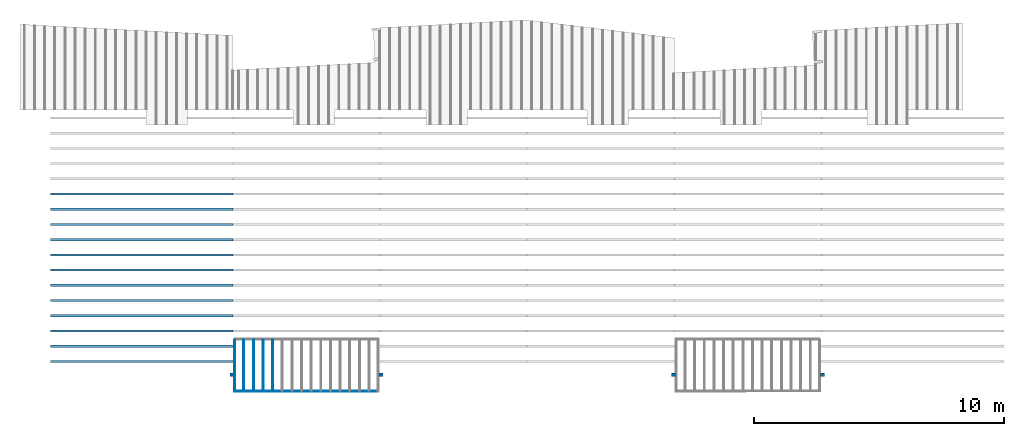
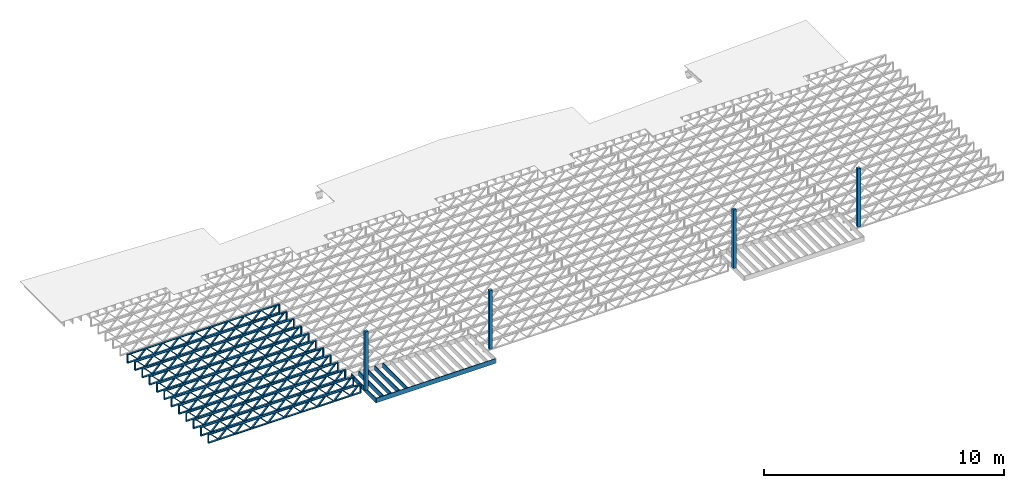
# One storey, part 1 of 12: 18 beams, 4 columns, 2 elements without a shape of their own.
"""IFC4 building model written with IfcOpenShell, lengths in feet."""

from ifc_helpers import new_model, entity, si_unit, converted_unit, derived_unit, direction, frame, frame_2d, origin, origin_2d_with_axis, place, context, subcontext, project, spatial, rectangle, extrude, source, transform, mapped, material, material_profile, profile_set, profile_usage, type_object, type_shapes, element, aggregate, save


model = new_model("IFC4")

# Units and contexts
model_context = context("Model", 3, precision=0.0001, world=origin(), true_north=direction((6.12303176911189e-17, 1.0)))
body_context = subcontext(model_context, "Body", "Model", "MODEL_VIEW")
ifc_project = project(units=[converted_unit("LENGTHUNIT", "FOOT", entity("IfcRatioMeasure", 0.3048), si_unit("LENGTHUNIT", "METRE"), dimensions=[1, 0, 0, 0, 0, 0, 0]), converted_unit("AREAUNIT", "SQUARE FOOT", entity("IfcRatioMeasure", 0.09290304), si_unit("AREAUNIT", "SQUARE_METRE"), dimensions=[2, 0, 0, 0, 0, 0, 0]), converted_unit("VOLUMEUNIT", "CUBIC FOOT", entity("IfcRatioMeasure", 0.028316846592), si_unit("VOLUMEUNIT", "CUBIC_METRE"), dimensions=[3, 0, 0, 0, 0, 0, 0]), converted_unit("PLANEANGLEUNIT", "DEGREE", entity("IfcRatioMeasure", 0.0174532925199433), si_unit("PLANEANGLEUNIT", "RADIAN"), dimensions=[0, 0, 0, 0, 0, 0, 0]), si_unit("MASSUNIT", "GRAM", prefix="KILO"), derived_unit("MASSDENSITYUNIT", [(si_unit("MASSUNIT", "GRAM", prefix="KILO"), 1), (si_unit("LENGTHUNIT", "METRE"), -3)]), derived_unit("MOMENTOFINERTIAUNIT", [(si_unit("LENGTHUNIT", "METRE"), 4)]), si_unit("TIMEUNIT", "SECOND"), si_unit("FREQUENCYUNIT", "HERTZ"), si_unit("THERMODYNAMICTEMPERATUREUNIT", "DEGREE_CELSIUS"), derived_unit("THERMALTRANSMITTANCEUNIT", [(si_unit("MASSUNIT", "GRAM", prefix="KILO"), 1), (si_unit("THERMODYNAMICTEMPERATUREUNIT", "KELVIN"), -1), (si_unit("TIMEUNIT", "SECOND"), -3)]), derived_unit("VOLUMETRICFLOWRATEUNIT", [(si_unit("LENGTHUNIT", "METRE"), 3), (si_unit("TIMEUNIT", "SECOND"), -1)]), si_unit("ELECTRICCURRENTUNIT", "AMPERE"), si_unit("ELECTRICVOLTAGEUNIT", "VOLT"), si_unit("POWERUNIT", "WATT"), si_unit("FORCEUNIT", "NEWTON"), si_unit("ILLUMINANCEUNIT", "LUX"), si_unit("LUMINOUSFLUXUNIT", "LUMEN"), si_unit("LUMINOUSINTENSITYUNIT", "CANDELA"), derived_unit("USERDEFINED", [(si_unit("MASSUNIT", "GRAM", prefix="KILO"), -1), (si_unit("LENGTHUNIT", "METRE"), -2), (si_unit("TIMEUNIT", "SECOND"), 3), (si_unit("LUMINOUSFLUXUNIT", "LUMEN"), 1)]), derived_unit("LINEARVELOCITYUNIT", [(si_unit("LENGTHUNIT", "METRE"), 1), (si_unit("TIMEUNIT", "SECOND"), -1)]), si_unit("PRESSUREUNIT", "PASCAL"), derived_unit("USERDEFINED", [(si_unit("LENGTHUNIT", "METRE"), -2), (si_unit("MASSUNIT", "GRAM", prefix="KILO"), 1), (si_unit("TIMEUNIT", "SECOND"), -2)]), derived_unit("LINEARFORCEUNIT", [(si_unit("MASSUNIT", "GRAM", prefix="KILO"), 1), (si_unit("LENGTHUNIT", "METRE"), 1), (si_unit("TIMEUNIT", "SECOND"), -2), (si_unit("LENGTHUNIT", "METRE"), -1)]), derived_unit("PLANARFORCEUNIT", [(si_unit("MASSUNIT", "GRAM", prefix="KILO"), 1), (si_unit("LENGTHUNIT", "METRE"), 1), (si_unit("TIMEUNIT", "SECOND"), -2), (si_unit("LENGTHUNIT", "METRE"), -2)])], contexts=[model_context])

# Site, building, storey
site_placement = place(None, origin())
site = spatial("IfcSite", under=ifc_project, at=site_placement, CompositionType="ELEMENT")
building_placement = place(site_placement, origin())
building = spatial("IfcBuilding", under=site, at=building_placement, CompositionType="ELEMENT")
storey_placement = place(building_placement, frame((0.0, 0.0, 21.46875)))
storey = spatial("IfcBuildingStorey", under=building, at=storey_placement, Name="3RD FLOOR", CompositionType="ELEMENT", Elevation=21.46875)

# Columns
ifc_material_1 = material(Name="STRUCTURAL WOOD COLUMN - SIZE TBD", Category="Materials")
ifc_material_profile_1 = material_profile(ifc_material_1, rectangle(XDim=0.458333333333333, YDim=0.5, at=frame_2d((0.0, -2.77555756156289e-17), x_axis=(1.0, 0.0))), Name="(4) 2X6 - BUILT-UP COLUMN")
ifc_profile_set_1 = profile_set([ifc_material_profile_1], Name="(4) 2X6 - BUILT-UP COLUMN")
ifc_profile_usage_1 = profile_usage(ifc_profile_set_1)
column_type = type_object("IfcColumnType", Name="Timber-Column:(4) 2X6 - BUILT-UP COLUMN", PredefinedType="COLUMN", material=ifc_profile_set_1)
shared_shape_1 = source(origin(), body_context, "Body", "SweptSolid", [
    extrude(rectangle(XDim=0.458333333333333, YDim=0.5, at=frame_2d((0.0, -2.77555756156289e-17), x_axis=(1.0, 0.0))), frame((0.0, 0.0, 21.46875), z_axis=(0.0, 0.0, 1.0), x_axis=(0.0, -1.0, 0.0)), (0.0, 0.0, 1.0), 9.73958333334152),
])
type_shapes(column_type, [shared_shape_1])
column_1_placement = place(storey_placement, frame((-241.863160485529, 924.091101549317, -21.46875)))
element("IfcColumn", 1, at=column_1_placement, inside=storey, type_object=column_type, material=ifc_profile_usage_1, Name="Timber-Column:(4) 2X6 - BUILT-UP COLUMN", ObjectType="Timber-Column:(4) 2X6 - BUILT-UP COLUMN", PredefinedType="COLUMN", context=body_context, shape_type="MappedRepresentation", body=[
    mapped(shared_shape_1, transform((0.0, 0.0, 0.0), scale=1.0)),
])
ifc_profile_usage_2 = profile_usage(ifc_profile_set_1)
column_2_placement = place(storey_placement, frame((-222.279828726425, 924.091101549317, -21.46875)))
element("IfcColumn", 2, at=column_2_placement, inside=storey, type_object=column_type, material=ifc_profile_usage_2, Name="Timber-Column:(4) 2X6 - BUILT-UP COLUMN", ObjectType="Timber-Column:(4) 2X6 - BUILT-UP COLUMN", PredefinedType="COLUMN", context=body_context, shape_type="MappedRepresentation", body=[
    mapped(shared_shape_1, transform((0.0, 0.0, 0.0), scale=1.0)),
])
ifc_profile_usage_3 = profile_usage(ifc_profile_set_1)
column_3_placement = place(storey_placement, frame((-183.863160485529, 924.091101549317, -21.46875)))
element("IfcColumn", 3, at=column_3_placement, inside=storey, type_object=column_type, material=ifc_profile_usage_3, Name="Timber-Column:(4) 2X6 - BUILT-UP COLUMN", ObjectType="Timber-Column:(4) 2X6 - BUILT-UP COLUMN", PredefinedType="COLUMN", context=body_context, shape_type="MappedRepresentation", body=[
    mapped(shared_shape_1, transform((0.0, 0.0, 0.0), scale=1.0)),
])
ifc_profile_usage_4 = profile_usage(ifc_profile_set_1)
column_4_placement = place(storey_placement, frame((-164.279827152195, 924.091101549317, -21.46875)))
element("IfcColumn", 4, at=column_4_placement, inside=storey, type_object=column_type, material=ifc_profile_usage_4, Name="Timber-Column:(4) 2X6 - BUILT-UP COLUMN", ObjectType="Timber-Column:(4) 2X6 - BUILT-UP COLUMN", PredefinedType="COLUMN", context=body_context, shape_type="MappedRepresentation", body=[
    mapped(shared_shape_1, transform((0.0, 0.0, 0.0), scale=1.0)),
])

# Assembly, beams
assembly_1_placement = place(storey_placement, origin())
assembly_1 = element("IfcElementAssembly", 5, at=assembly_1_placement, inside=storey, Name="Structural Beam System:Structural Framing System", ObjectType="Structural Beam System:Structural Framing System", AssemblyPlace="NOTDEFINED", PredefinedType="BEAM_GRID")
ifc_material_2 = material(Category="Materials")
ifc_material_profile_2 = material_profile(ifc_material_2, rectangle(XDim=0.770833333333333, YDim=0.124999999999994, at=frame_2d((-5.55111512312578e-17, 0.0), x_axis=(1.0, 0.0))))
ifc_profile_set_2 = profile_set([ifc_material_profile_2])
ifc_profile_usage_5 = profile_usage(ifc_profile_set_2, cardinal=8)
beam_type_1 = type_object("IfcBeamType", PredefinedType="BEAM", material=ifc_profile_set_2)
shared_shape_2 = source(origin(), body_context, "Body", "SweptSolid", [
    extrude(rectangle(XDim=0.770833333333333, YDim=0.124999999999994, at=frame_2d((-5.55111512312578e-17, 0.0), x_axis=(1.0, 0.0))), frame((-3.35416666666737, 0.0, 0.0), z_axis=(1.0, 0.0, 0.0), x_axis=(0.0, 0.0, -1.0)), (0.0, 0.0, 1.0), 6.70833333333462),
])
type_shapes(beam_type_1, [shared_shape_2])
beam_1_placement = place(assembly_1_placement, frame((-240.307864400484, 925.341101549316, -0.645833333333474), z_axis=(0.0, 0.0, 1.0), x_axis=(0.0, 1.0, 0.0)))
beam_1 = element("IfcBeam", 6, at=beam_1_placement, type_object=beam_type_1, material=ifc_profile_usage_5, PredefinedType="BEAM", context=body_context, shape_type="MappedRepresentation", body=[
    mapped(shared_shape_2, transform((0.0, 0.0, 0.0), scale=1.0)),
])
ifc_profile_usage_6 = profile_usage(ifc_profile_set_2, cardinal=8)
beam_2_placement = place(assembly_1_placement, frame((-239.040980719926, 925.341101549316, -0.645833333333474), z_axis=(0.0, 0.0, 1.0), x_axis=(0.0, 1.0, 0.0)))
beam_2 = element("IfcBeam", 7, at=beam_2_placement, type_object=beam_type_1, material=ifc_profile_usage_6, PredefinedType="BEAM", context=body_context, shape_type="MappedRepresentation", body=[
    mapped(shared_shape_2, transform((0.0, 0.0, 0.0), scale=1.0)),
])
ifc_profile_usage_7 = profile_usage(ifc_profile_set_2, cardinal=8)
beam_3_placement = place(assembly_1_placement, frame((-237.774097039367, 925.341101549316, -0.645833333333474), z_axis=(0.0, 0.0, 1.0), x_axis=(0.0, 1.0, 0.0)))
beam_3 = element("IfcBeam", 8, at=beam_3_placement, type_object=beam_type_1, material=ifc_profile_usage_7, PredefinedType="BEAM", context=body_context, shape_type="MappedRepresentation", body=[
    mapped(shared_shape_2, transform((0.0, 0.0, 0.0), scale=1.0)),
])
ifc_profile_usage_8 = profile_usage(ifc_profile_set_2, cardinal=8)
beam_4_placement = place(assembly_1_placement, frame((-236.507213358809, 925.341101549317, -0.645833333333474), z_axis=(0.0, 0.0, 1.0), x_axis=(0.0, 1.0, 0.0)))
beam_4 = element("IfcBeam", 9, at=beam_4_placement, type_object=beam_type_1, material=ifc_profile_usage_8, PredefinedType="BEAM", context=body_context, shape_type="MappedRepresentation", body=[
    mapped(shared_shape_2, transform((0.0, 0.0, 0.0), scale=1.0)),
])
aggregate(assembly_1, [beam_1, beam_2, beam_3, beam_4])

assembly_2_placement = place(storey_placement, origin())
assembly_2 = element("IfcElementAssembly", 10, at=assembly_2_placement, inside=storey, Name="Structural Beam System:Structural Framing System", ObjectType="Structural Beam System:Structural Framing System", AssemblyPlace="NOTDEFINED", PredefinedType="BEAM_GRID")
ifc_material_3 = material(Name="WOOD TRUSS", Category="Materials")
ifc_material_profile_3 = material_profile(ifc_material_3, rectangle(XDim=1.73473973950632, YDim=0.125, at=frame_2d((-1.11022302462516e-16, 8.32667268468867e-17), x_axis=(1.0, 0.0))))
ifc_material_profile_4 = material_profile(ifc_material_3, rectangle(XDim=1.73473973950633, YDim=0.125, at=frame_2d((-1.11022302462516e-16, 8.32667268468867e-17), x_axis=(1.0, 0.0))))
ifc_material_profile_5 = material_profile(ifc_material_3, rectangle(XDim=1.73473973950632, YDim=0.125, at=frame_2d((-5.55111512312578e-17, 1.38777878078145e-16), x_axis=(1.0, 0.0))))
ifc_material_profile_6 = material_profile(ifc_material_3, rectangle(XDim=1.73473973950633, YDim=0.125, at=frame_2d((-1.11022302462516e-16, 8.32667268468867e-17), x_axis=(1.0, 0.0))))
ifc_material_profile_7 = material_profile(ifc_material_3, rectangle(XDim=1.73473973950632, YDim=0.125, at=frame_2d((-1.11022302462516e-16, 8.32667268468867e-17), x_axis=(1.0, 0.0))))
ifc_material_profile_8 = material_profile(ifc_material_3, rectangle(XDim=1.73473973950633, YDim=0.125, at=frame_2d((-2.77555756156289e-16, 3.05311331771918e-16), x_axis=(1.0, 0.0))))
ifc_material_profile_9 = material_profile(ifc_material_3, rectangle(XDim=1.73473973950632, YDim=0.124999999999999, at=frame_2d((-3.88578058618805e-16, -2.4980018054066e-16), x_axis=(1.0, 0.0))))
ifc_material_profile_10 = material_profile(ifc_material_3, rectangle(XDim=1.73473973950633, YDim=0.125, at=frame_2d((2.77555756156289e-16, -3.05311331771918e-16), x_axis=(1.0, 0.0))))
ifc_material_profile_11 = material_profile(ifc_material_3, rectangle(XDim=1.73473973950632, YDim=0.124999999999999, at=frame_2d((-1.11022302462516e-16, 8.32667268468867e-17), x_axis=(1.0, 0.0))))
ifc_material_profile_12 = material_profile(ifc_material_3, rectangle(XDim=1.73473973950633, YDim=0.125, at=origin_2d_with_axis()))
ifc_material_profile_13 = material_profile(ifc_material_3, rectangle(XDim=0.124999999999982, YDim=0.291666666666668, at=origin_2d_with_axis()))
ifc_material_profile_14 = material_profile(ifc_material_3, rectangle(XDim=0.124999999999932, YDim=0.291666666666664, at=origin_2d_with_axis()))
ifc_material_profile_15 = material_profile(ifc_material_3, rectangle(XDim=1.25000000000002, YDim=0.29166666666667, at=origin_2d_with_axis()))
ifc_material_profile_16 = material_profile(ifc_material_3, rectangle(XDim=1.25000000000004, YDim=0.291666666666667, at=origin_2d_with_axis()))
ifc_profile_set_3 = profile_set([ifc_material_profile_3, ifc_material_profile_4, ifc_material_profile_5, ifc_material_profile_6, ifc_material_profile_7, ifc_material_profile_8, ifc_material_profile_9, ifc_material_profile_10, ifc_material_profile_11, ifc_material_profile_12, ifc_material_profile_13, ifc_material_profile_14, ifc_material_profile_15, ifc_material_profile_16])
ifc_profile_usage_9 = profile_usage(ifc_profile_set_3, cardinal=8)
beam_type_2 = type_object("IfcBeamType", PredefinedType="BEAM", material=ifc_profile_set_3)
shared_shape_3 = source(origin(), body_context, "Body", "SweptSolid", [
    extrude(rectangle(XDim=1.73473973950632, YDim=0.124999999999999, at=frame_2d((5.55111512312578e-16, 7.21644966006352e-16), x_axis=(1.0, 0.0))), frame((8.37514585578398, -0.145833333333334, 0.0), z_axis=(0.0, 1.0, 0.0), x_axis=(0.693383046997606, 0.0, 0.720569184836762)), (0.0, 0.0, 1.0), 0.291666666666667),
    extrude(rectangle(XDim=1.73473973950633, YDim=0.125, at=origin_2d_with_axis()), frame((7.12485998211071, -0.145833333333334, 0.0), z_axis=(0.0, 1.0, 0.0), x_axis=(0.69338304699761, 0.0, -0.720569184836758)), (0.0, 0.0, 1.0), 0.291666666666666),
    extrude(rectangle(XDim=1.73473973950632, YDim=0.124999999999999, at=frame_2d((-1.11022302462516e-16, 8.32667268468867e-17), x_axis=(1.0, 0.0))), frame((5.79181154946831, -0.145833333333334, 0.0), z_axis=(0.0, 1.0, 0.0), x_axis=(0.693383046997606, 0.0, 0.720569184836762)), (0.0, 0.0, 1.0), 0.291666666666667),
    extrude(rectangle(XDim=1.73473973950633, YDim=0.125, at=origin_2d_with_axis()), frame((4.54152567579504, -0.145833333333334, 0.0), z_axis=(0.0, 1.0, 0.0), x_axis=(0.69338304699761, 0.0, -0.720569184836758)), (0.0, 0.0, 1.0), 0.291666666666666),
    extrude(rectangle(XDim=1.73473973950632, YDim=0.125, at=frame_2d((2.22044604925031e-16, 3.88578058618805e-16), x_axis=(1.0, 0.0))), frame((3.20847724315264, -0.145833333333334, 0.0), z_axis=(0.0, 1.0, 0.0), x_axis=(0.693383046997606, 0.0, 0.720569184836762)), (0.0, 0.0, 1.0), 0.291666666666667),
    extrude(rectangle(XDim=1.73473973950633, YDim=0.125, at=frame_2d((-1.11022302462516e-16, 8.32667268468867e-17), x_axis=(1.0, 0.0))), frame((1.95819136947937, -0.145833333333334, 0.0), z_axis=(0.0, 1.0, 0.0), x_axis=(0.69338304699761, 0.0, -0.720569184836758)), (0.0, 0.0, 1.0), 0.291666666666667),
    extrude(rectangle(XDim=1.73473973950632, YDim=0.125, at=frame_2d((-5.55111512312578e-17, 1.38777878078145e-16), x_axis=(1.0, 0.0))), frame((0.625142936836964, -0.145833333333334, 0.0), z_axis=(0.0, 1.0, 0.0), x_axis=(0.693383046997606, 0.0, 0.720569184836762)), (0.0, 0.0, 1.0), 0.291666666666667),
    extrude(rectangle(XDim=1.73473973950633, YDim=0.125, at=frame_2d((-1.11022302462516e-16, 8.32667268468867e-17), x_axis=(1.0, 0.0))), frame((-0.625142936836306, -0.145833333333334, 0.0), z_axis=(0.0, 1.0, 0.0), x_axis=(0.69338304699761, 0.0, -0.720569184836758)), (0.0, 0.0, 1.0), 0.291666666666667),
    extrude(rectangle(XDim=1.73473973950632, YDim=0.125, at=frame_2d((-1.11022302462516e-16, 8.32667268468867e-17), x_axis=(1.0, 0.0))), frame((-1.95819136947871, -0.145833333333334, 0.0), z_axis=(0.0, 1.0, 0.0), x_axis=(0.693383046997606, 0.0, 0.720569184836762)), (0.0, 0.0, 1.0), 0.291666666666667),
    extrude(rectangle(XDim=1.73473973950633, YDim=0.125, at=origin_2d_with_axis()), frame((-3.20847724315198, -0.145833333333334, 0.0), z_axis=(0.0, 1.0, 0.0), x_axis=(0.69338304699761, 0.0, -0.720569184836758)), (0.0, 0.0, 1.0), 0.291666666666667),
    extrude(rectangle(XDim=1.73473973950632, YDim=0.124999999999999, at=frame_2d((-1.11022302462516e-16, 8.32667268468867e-17), x_axis=(1.0, 0.0))), frame((-4.54152567579438, -0.145833333333334, 0.0), z_axis=(0.0, 1.0, 0.0), x_axis=(0.693383046997606, 0.0, 0.720569184836762)), (0.0, 0.0, 1.0), 0.291666666666667),
    extrude(rectangle(XDim=1.73473973950633, YDim=0.125, at=origin_2d_with_axis()), frame((-5.79181154946765, -0.145833333333334, 0.0), z_axis=(0.0, 1.0, 0.0), x_axis=(0.69338304699761, 0.0, -0.720569184836758)), (0.0, 0.0, 1.0), 0.291666666666666),
    extrude(rectangle(XDim=1.73473973950632, YDim=0.124999999999999, at=frame_2d((-1.11022302462516e-16, 8.32667268468867e-17), x_axis=(1.0, 0.0))), frame((-7.12485998211005, -0.145833333333334, 0.0), z_axis=(0.0, 1.0, 0.0), x_axis=(0.693383046997606, 0.0, 0.720569184836762)), (0.0, 0.0, 1.0), 0.291666666666667),
    extrude(rectangle(XDim=1.73473973950633, YDim=0.125, at=frame_2d((-2.77555756156289e-16, 3.05311331771918e-16), x_axis=(1.0, 0.0))), frame((-8.37514585578332, -0.145833333333334, 0.0), z_axis=(0.0, 1.0, 0.0), x_axis=(0.69338304699761, 0.0, -0.720569184836758)), (0.0, 0.0, 1.0), 0.291666666666666),
    extrude(rectangle(XDim=1.73473973950632, YDim=0.125, at=frame_2d((-7.21644966006352e-16, -5.55111512312578e-16), x_axis=(1.0, 0.0))), frame((10.9584801620997, -0.145833333333334, 0.0), z_axis=(0.0, 1.0, 0.0), x_axis=(0.693383046997606, 0.0, 0.720569184836762)), (0.0, 0.0, 1.0), 0.291666666666667),
    extrude(rectangle(XDim=1.73473973950633, YDim=0.125, at=origin_2d_with_axis()), frame((9.70819428842638, -0.145833333333334, 0.0), z_axis=(0.0, 1.0, 0.0), x_axis=(0.69338304699761, 0.0, -0.720569184836758)), (0.0, 0.0, 1.0), 0.291666666666666),
    extrude(rectangle(XDim=1.73473973950632, YDim=0.125, at=frame_2d((-5.55111512312578e-17, 8.32667268468867e-17), x_axis=(1.0, 0.0))), frame((-9.70819428842572, -0.145833333333334, 0.0), z_axis=(0.0, 1.0, 0.0), x_axis=(0.693383046997606, 0.0, 0.720569184836762)), (0.0, 0.0, 1.0), 0.291666666666667),
    extrude(rectangle(XDim=1.73473973950633, YDim=0.125, at=origin_2d_with_axis()), frame((-10.958480162099, -0.145833333333334, 0.0), z_axis=(0.0, 1.0, 0.0), x_axis=(0.69338304699761, 0.0, -0.720569184836758)), (0.0, 0.0, 1.0), 0.291666666666666),
    extrude(rectangle(XDim=0.124999999999982, YDim=0.291666666666668, at=origin_2d_with_axis()), frame((-12.0000038919293, 0.0, 0.687500000000054), z_axis=(1.0, 0.0, 0.0), x_axis=(0.0, 0.0, -1.0)), (0.0, 0.0, 1.0), 24.0000077838585),
    extrude(rectangle(XDim=0.124999999999932, YDim=0.291666666666664, at=origin_2d_with_axis()), frame((-12.0000038919291, 0.0, -0.687499999999984), z_axis=(1.0, 0.0, 0.0), x_axis=(0.0, 0.0, -1.0)), (0.0, 0.0, 1.0), 24.0000077838583),
    extrude(rectangle(XDim=1.25000000000002, YDim=0.29166666666667, at=origin_2d_with_axis()), frame((11.8750038919292, 0.0, 0.0), z_axis=(1.0, 0.0, 0.0), x_axis=(0.0, 0.0, -1.0)), (0.0, 0.0, 1.0), 0.12500000000002),
    extrude(rectangle(XDim=1.25000000000004, YDim=0.291666666666667, at=origin_2d_with_axis()), frame((-12.0000038919293, 0.0, 0.0), z_axis=(1.0, 0.0, 0.0), x_axis=(0.0, 0.0, -1.0)), (0.0, 0.0, 1.0), 0.125000000000023),
])
type_shapes(beam_type_2, [shared_shape_3])
beam_5_placement = place(assembly_2_placement, frame((-253.738164405664, 947.861934882651, -0.947916666657857)))
beam_5 = element("IfcBeam", 11, at=beam_5_placement, type_object=beam_type_2, material=ifc_profile_usage_9, PredefinedType="BEAM", context=body_context, shape_type="MappedRepresentation", body=[
    mapped(shared_shape_3, transform((0.0, 0.0, 0.0), scale=1.0)),
])
ifc_profile_usage_10 = profile_usage(ifc_profile_set_3, cardinal=8)
beam_6_placement = place(assembly_2_placement, frame((-253.738164405664, 945.861934882651, -0.947916666657857)))
beam_6 = element("IfcBeam", 12, at=beam_6_placement, type_object=beam_type_2, material=ifc_profile_usage_10, PredefinedType="BEAM", context=body_context, shape_type="MappedRepresentation", body=[
    mapped(shared_shape_3, transform((0.0, 0.0, 0.0), scale=1.0)),
])
ifc_profile_usage_11 = profile_usage(ifc_profile_set_3, cardinal=8)
beam_7_placement = place(assembly_2_placement, frame((-253.738164405664, 943.861934882651, -0.947916666657857)))
beam_7 = element("IfcBeam", 13, at=beam_7_placement, type_object=beam_type_2, material=ifc_profile_usage_11, PredefinedType="BEAM", context=body_context, shape_type="MappedRepresentation", body=[
    mapped(shared_shape_3, transform((0.0, 0.0, 0.0), scale=1.0)),
])
ifc_profile_usage_12 = profile_usage(ifc_profile_set_3, cardinal=8)
beam_8_placement = place(assembly_2_placement, frame((-253.738164405664, 941.861934882651, -0.947916666657857)))
beam_8 = element("IfcBeam", 14, at=beam_8_placement, type_object=beam_type_2, material=ifc_profile_usage_12, PredefinedType="BEAM", context=body_context, shape_type="MappedRepresentation", body=[
    mapped(shared_shape_3, transform((0.0, 0.0, 0.0), scale=1.0)),
])
ifc_profile_usage_13 = profile_usage(ifc_profile_set_3, cardinal=8)
beam_9_placement = place(assembly_2_placement, frame((-253.738164405664, 939.861934882651, -0.947916666657857)))
beam_9 = element("IfcBeam", 15, at=beam_9_placement, type_object=beam_type_2, material=ifc_profile_usage_13, PredefinedType="BEAM", context=body_context, shape_type="MappedRepresentation", body=[
    mapped(shared_shape_3, transform((0.0, 0.0, 0.0), scale=1.0)),
])
ifc_profile_usage_14 = profile_usage(ifc_profile_set_3, cardinal=8)
beam_10_placement = place(assembly_2_placement, frame((-253.738164405664, 937.861934882651, -0.947916666657857)))
beam_10 = element("IfcBeam", 16, at=beam_10_placement, type_object=beam_type_2, material=ifc_profile_usage_14, PredefinedType="BEAM", context=body_context, shape_type="MappedRepresentation", body=[
    mapped(shared_shape_3, transform((0.0, 0.0, 0.0), scale=1.0)),
])
ifc_profile_usage_15 = profile_usage(ifc_profile_set_3, cardinal=8)
beam_11_placement = place(assembly_2_placement, frame((-253.738164405664, 935.861934882651, -0.947916666657857)))
beam_11 = element("IfcBeam", 17, at=beam_11_placement, type_object=beam_type_2, material=ifc_profile_usage_15, PredefinedType="BEAM", context=body_context, shape_type="MappedRepresentation", body=[
    mapped(shared_shape_3, transform((0.0, 0.0, 0.0), scale=1.0)),
])
ifc_profile_usage_16 = profile_usage(ifc_profile_set_3, cardinal=8)
beam_12_placement = place(assembly_2_placement, frame((-253.738164405664, 933.861934882651, -0.947916666657857)))
beam_12 = element("IfcBeam", 18, at=beam_12_placement, type_object=beam_type_2, material=ifc_profile_usage_16, PredefinedType="BEAM", context=body_context, shape_type="MappedRepresentation", body=[
    mapped(shared_shape_3, transform((0.0, 0.0, 0.0), scale=1.0)),
])
ifc_profile_usage_17 = profile_usage(ifc_profile_set_3, cardinal=8)
beam_13_placement = place(assembly_2_placement, frame((-253.738164405664, 931.861934882651, -0.947916666657857)))
beam_13 = element("IfcBeam", 19, at=beam_13_placement, type_object=beam_type_2, material=ifc_profile_usage_17, PredefinedType="BEAM", context=body_context, shape_type="MappedRepresentation", body=[
    mapped(shared_shape_3, transform((0.0, 0.0, 0.0), scale=1.0)),
])
ifc_profile_usage_18 = profile_usage(ifc_profile_set_3, cardinal=8)
beam_14_placement = place(assembly_2_placement, frame((-253.738164405664, 929.861934882651, -0.947916666657857)))
beam_14 = element("IfcBeam", 20, at=beam_14_placement, type_object=beam_type_2, material=ifc_profile_usage_18, PredefinedType="BEAM", context=body_context, shape_type="MappedRepresentation", body=[
    mapped(shared_shape_3, transform((0.0, 0.0, 0.0), scale=1.0)),
])
ifc_profile_usage_19 = profile_usage(ifc_profile_set_3, cardinal=8)
beam_type_3 = type_object("IfcBeamType", PredefinedType="BEAM", material=ifc_profile_set_3)
shared_shape_4 = source(origin(), body_context, "Body", "SweptSolid", [
    extrude(rectangle(XDim=1.73473973950632, YDim=0.124999999999999, at=frame_2d((5.55111512312578e-16, 7.21644966006352e-16), x_axis=(1.0, 0.0))), frame((8.42202085580899, -0.145833333333334, 0.0), z_axis=(0.0, 1.0, 0.0), x_axis=(0.693383046997606, 0.0, 0.720569184836762)), (0.0, 0.0, 1.0), 0.291666666666667),
    extrude(rectangle(XDim=1.73473973950633, YDim=0.125, at=origin_2d_with_axis()), frame((7.17173498213572, -0.145833333333334, 0.0), z_axis=(0.0, 1.0, 0.0), x_axis=(0.69338304699761, 0.0, -0.720569184836758)), (0.0, 0.0, 1.0), 0.291666666666666),
    extrude(rectangle(XDim=1.73473973950632, YDim=0.124999999999999, at=frame_2d((-1.11022302462516e-16, 8.32667268468867e-17), x_axis=(1.0, 0.0))), frame((5.82306154948498, -0.145833333333334, 0.0), z_axis=(0.0, 1.0, 0.0), x_axis=(0.693383046997606, 0.0, 0.720569184836762)), (0.0, 0.0, 1.0), 0.291666666666667),
    extrude(rectangle(XDim=1.73473973950633, YDim=0.125, at=origin_2d_with_axis()), frame((4.57277567581171, -0.145833333333334, 0.0), z_axis=(0.0, 1.0, 0.0), x_axis=(0.69338304699761, 0.0, -0.720569184836758)), (0.0, 0.0, 1.0), 0.291666666666666),
    extrude(rectangle(XDim=1.73473973950632, YDim=0.125, at=frame_2d((2.22044604925031e-16, 3.88578058618805e-16), x_axis=(1.0, 0.0))), frame((3.22410224316097, -0.145833333333334, 0.0), z_axis=(0.0, 1.0, 0.0), x_axis=(0.693383046997606, 0.0, 0.720569184836762)), (0.0, 0.0, 1.0), 0.291666666666667),
    extrude(rectangle(XDim=1.73473973950633, YDim=0.125, at=frame_2d((-1.11022302462516e-16, 8.32667268468867e-17), x_axis=(1.0, 0.0))), frame((1.9738163694877, -0.145833333333334, 0.0), z_axis=(0.0, 1.0, 0.0), x_axis=(0.69338304699761, 0.0, -0.720569184836758)), (0.0, 0.0, 1.0), 0.291666666666667),
    extrude(rectangle(XDim=1.73473973950632, YDim=0.125, at=frame_2d((-5.55111512312578e-17, 1.38777878078145e-16), x_axis=(1.0, 0.0))), frame((0.625142936836964, -0.145833333333334, 0.0), z_axis=(0.0, 1.0, 0.0), x_axis=(0.693383046997606, 0.0, 0.720569184836762)), (0.0, 0.0, 1.0), 0.291666666666667),
    extrude(rectangle(XDim=1.73473973950633, YDim=0.125, at=frame_2d((-1.11022302462516e-16, 8.32667268468867e-17), x_axis=(1.0, 0.0))), frame((-0.625142936836306, -0.145833333333334, 0.0), z_axis=(0.0, 1.0, 0.0), x_axis=(0.69338304699761, 0.0, -0.720569184836758)), (0.0, 0.0, 1.0), 0.291666666666667),
    extrude(rectangle(XDim=1.73473973950632, YDim=0.125, at=frame_2d((-1.11022302462516e-16, 8.32667268468867e-17), x_axis=(1.0, 0.0))), frame((-1.97381636948704, -0.145833333333334, 0.0), z_axis=(0.0, 1.0, 0.0), x_axis=(0.693383046997606, 0.0, 0.720569184836762)), (0.0, 0.0, 1.0), 0.291666666666667),
    extrude(rectangle(XDim=1.73473973950633, YDim=0.125, at=origin_2d_with_axis()), frame((-3.22410224316031, -0.145833333333334, 0.0), z_axis=(0.0, 1.0, 0.0), x_axis=(0.69338304699761, 0.0, -0.720569184836758)), (0.0, 0.0, 1.0), 0.291666666666667),
    extrude(rectangle(XDim=1.73473973950632, YDim=0.124999999999999, at=frame_2d((-1.11022302462516e-16, 8.32667268468867e-17), x_axis=(1.0, 0.0))), frame((-4.57277567581105, -0.145833333333334, 0.0), z_axis=(0.0, 1.0, 0.0), x_axis=(0.693383046997606, 0.0, 0.720569184836762)), (0.0, 0.0, 1.0), 0.291666666666667),
    extrude(rectangle(XDim=1.73473973950633, YDim=0.125, at=origin_2d_with_axis()), frame((-5.82306154948432, -0.145833333333334, 0.0), z_axis=(0.0, 1.0, 0.0), x_axis=(0.69338304699761, 0.0, -0.720569184836758)), (0.0, 0.0, 1.0), 0.291666666666666),
    extrude(rectangle(XDim=1.73473973950632, YDim=0.124999999999999, at=frame_2d((-1.11022302462516e-16, 8.32667268468867e-17), x_axis=(1.0, 0.0))), frame((-7.17173498213506, -0.145833333333334, 0.0), z_axis=(0.0, 1.0, 0.0), x_axis=(0.693383046997606, 0.0, 0.720569184836762)), (0.0, 0.0, 1.0), 0.291666666666667),
    extrude(rectangle(XDim=1.73473973950633, YDim=0.125, at=frame_2d((-2.77555756156289e-16, 3.05311331771918e-16), x_axis=(1.0, 0.0))), frame((-8.42202085580833, -0.145833333333334, 0.0), z_axis=(0.0, 1.0, 0.0), x_axis=(0.69338304699761, 0.0, -0.720569184836758)), (0.0, 0.0, 1.0), 0.291666666666666),
    extrude(rectangle(XDim=1.73473973950632, YDim=0.125, at=frame_2d((-7.21644966006352e-16, -5.55111512312578e-16), x_axis=(1.0, 0.0))), frame((11.020980162133, -0.145833333333334, 0.0), z_axis=(0.0, 1.0, 0.0), x_axis=(0.693383046997606, 0.0, 0.720569184836762)), (0.0, 0.0, 1.0), 0.291666666666667),
    extrude(rectangle(XDim=1.73473973950633, YDim=0.125, at=origin_2d_with_axis()), frame((9.77069428845972, -0.145833333333334, 0.0), z_axis=(0.0, 1.0, 0.0), x_axis=(0.69338304699761, 0.0, -0.720569184836758)), (0.0, 0.0, 1.0), 0.291666666666666),
    extrude(rectangle(XDim=1.73473973950632, YDim=0.125, at=frame_2d((-5.55111512312578e-17, 8.32667268468867e-17), x_axis=(1.0, 0.0))), frame((-9.77069428845906, -0.145833333333334, 0.0), z_axis=(0.0, 1.0, 0.0), x_axis=(0.693383046997606, 0.0, 0.720569184836762)), (0.0, 0.0, 1.0), 0.291666666666667),
    extrude(rectangle(XDim=1.73473973950633, YDim=0.125, at=origin_2d_with_axis()), frame((-11.0209801621323, -0.145833333333334, 0.0), z_axis=(0.0, 1.0, 0.0), x_axis=(0.69338304699761, 0.0, -0.720569184836758)), (0.0, 0.0, 1.0), 0.291666666666666),
    extrude(rectangle(XDim=0.124999999999982, YDim=0.291666666666668, at=origin_2d_with_axis()), frame((-12.0625038919626, 0.0, 0.687500000000054), z_axis=(1.0, 0.0, 0.0), x_axis=(0.0, 0.0, -1.0)), (0.0, 0.0, 1.0), 24.1250077839252),
    extrude(rectangle(XDim=0.124999999999932, YDim=0.291666666666664, at=origin_2d_with_axis()), frame((-12.0625038919624, 0.0, -0.687499999999984), z_axis=(1.0, 0.0, 0.0), x_axis=(0.0, 0.0, -1.0)), (0.0, 0.0, 1.0), 24.125007783925),
    extrude(rectangle(XDim=1.25000000000002, YDim=0.29166666666667, at=origin_2d_with_axis()), frame((11.9375038919626, 0.0, 0.0), z_axis=(1.0, 0.0, 0.0), x_axis=(0.0, 0.0, -1.0)), (0.0, 0.0, 1.0), 0.12500000000002),
    extrude(rectangle(XDim=1.25000000000004, YDim=0.291666666666667, at=origin_2d_with_axis()), frame((-12.0625038919626, 0.0, 0.0), z_axis=(1.0, 0.0, 0.0), x_axis=(0.0, 0.0, -1.0)), (0.0, 0.0, 1.0), 0.125000000000023),
])
type_shapes(beam_type_3, [shared_shape_4])
beam_15_placement = place(assembly_2_placement, frame((-253.675664405631, 927.861934882651, -0.947916666657857)))
beam_15 = element("IfcBeam", 21, at=beam_15_placement, type_object=beam_type_3, material=ifc_profile_usage_19, PredefinedType="BEAM", context=body_context, shape_type="MappedRepresentation", body=[
    mapped(shared_shape_4, transform((0.0, 0.0, 0.0), scale=1.0)),
])
ifc_profile_usage_20 = profile_usage(ifc_profile_set_3, cardinal=8)
beam_16_placement = place(assembly_2_placement, frame((-253.675664405631, 925.861934882651, -0.947916666657857)))
beam_16 = element("IfcBeam", 22, at=beam_16_placement, type_object=beam_type_3, material=ifc_profile_usage_20, PredefinedType="BEAM", context=body_context, shape_type="MappedRepresentation", body=[
    mapped(shared_shape_4, transform((0.0, 0.0, 0.0), scale=1.0)),
])
aggregate(assembly_2, [beam_5, beam_6, beam_7, beam_8, beam_9, beam_10, beam_11, beam_12, beam_13, beam_14, beam_15, beam_16])

# Beams
ifc_profile_usage_21 = profile_usage(ifc_profile_set_2, cardinal=8)
beam_type_4 = type_object("IfcBeamType", PredefinedType="BEAM", material=ifc_profile_set_2)
shared_shape_5 = source(origin(), body_context, "Body", "SweptSolid", [
    extrude(rectangle(XDim=0.770833333333333, YDim=0.124999999999994, at=origin_2d_with_axis()), frame((-3.47916666666737, 0.0, 0.0), z_axis=(1.0, 0.0, 0.0), x_axis=(0.0, 0.0, -1.0)), (0.0, 0.0, 1.0), 6.83333333333471),
])
type_shapes(beam_type_4, [shared_shape_5])
beam_17_placement = place(storey_placement, frame((-241.508993604251, 925.341101549316, -0.645833333332799), z_axis=(0.0, 0.0, 1.0), x_axis=(0.0, 1.0, 0.0)))
element("IfcBeam", 23, at=beam_17_placement, inside=storey, type_object=beam_type_4, material=ifc_profile_usage_21, PredefinedType="BEAM", context=body_context, shape_type="MappedRepresentation", body=[
    mapped(shared_shape_5, transform((0.0, 0.0, 0.0), scale=1.0)),
])
ifc_material_4 = material(Name="BRAKE METAL FLASHING AT PERIMETER 2X LEDGER", Category="Materials")
ifc_material_profile_17 = material_profile(ifc_material_4, rectangle(XDim=0.770833333333333, YDim=0.124999999999994, at=frame_2d((-1.11022302462516e-16, 0.0), x_axis=(1.0, 0.0))), Name="BRAKE METAL FLASHING AT PERIMETER 2X LEDGER")
ifc_profile_set_4 = profile_set([ifc_material_profile_17], Name="BRAKE METAL FLASHING AT PERIMETER 2X LEDGER")
ifc_profile_usage_22 = profile_usage(ifc_profile_set_4, cardinal=8)
beam_type_5 = type_object("IfcBeamType", PredefinedType="BEAM", material=ifc_profile_set_4)
shared_shape_6 = source(origin(), body_context, "Body", "SweptSolid", [
    extrude(rectangle(XDim=0.770833333333333, YDim=0.124999999999994, at=origin_2d_with_axis()), frame((-9.37499887751909, 0.0, 0.0), z_axis=(1.0, 0.0, 0.0), x_axis=(0.0, 0.0, -1.0)), (0.0, 0.0, 1.0), 18.7499977550382),
])
type_shapes(beam_type_5, [shared_shape_6])
beam_18_placement = place(storey_placement, frame((-232.071494726732, 921.92443488265, -0.645833333333496), z_axis=(0.0, 0.0, 1.0), x_axis=(-1.0, 0.0, 0.0)))
element("IfcBeam", 24, at=beam_18_placement, inside=storey, type_object=beam_type_5, material=ifc_profile_usage_22, PredefinedType="BEAM", context=body_context, shape_type="MappedRepresentation", body=[
    mapped(shared_shape_6, transform((0.0, 0.0, 0.0), scale=1.0)),
])

save(model, "model.ifc")
